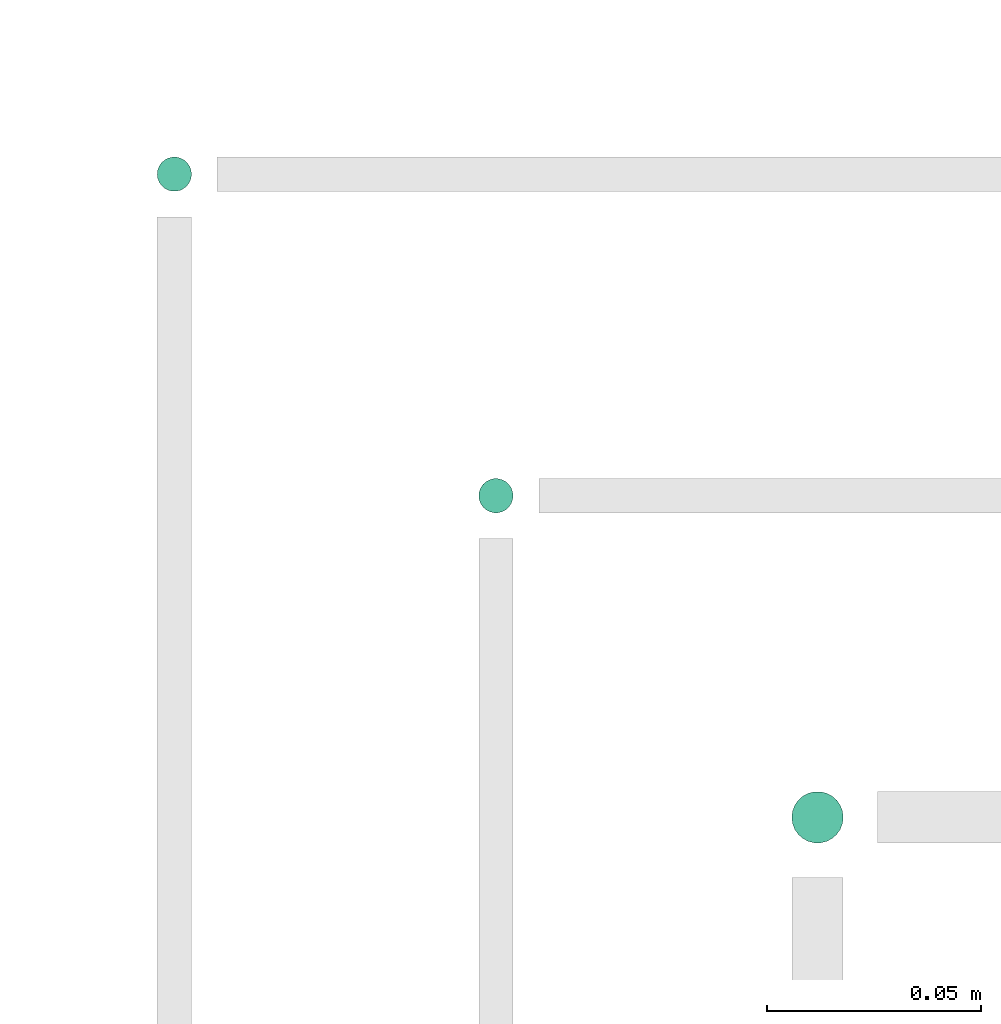
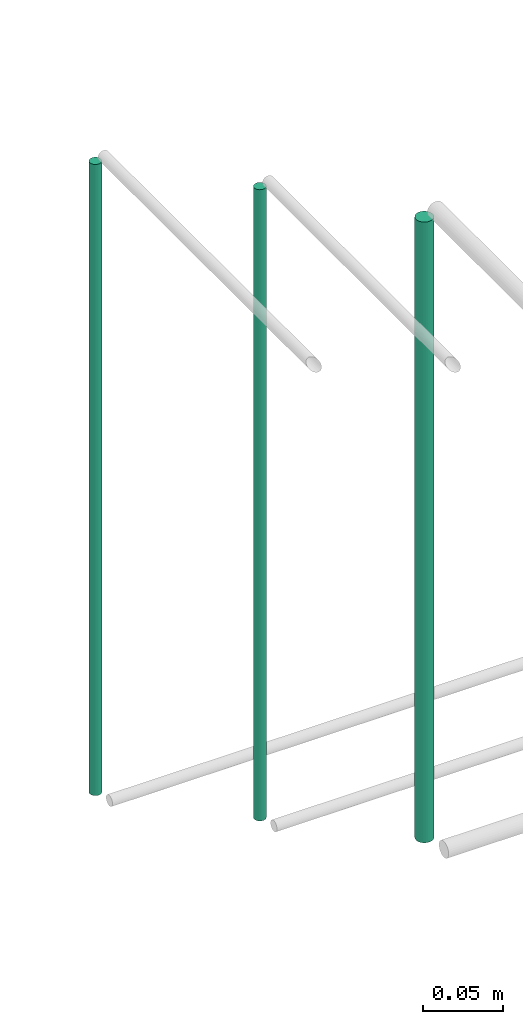
# One storey, part 30 of 65: 3 flow segments.
"""IFC2X3 building model written with IfcOpenShell, lengths in millimetres."""

from ifc_helpers import new_model, entity, si_unit, converted_unit, derived_unit, direction, frame, origin, origin_2d_with_axis, place, context, subcontext, project, spatial, circle, extrude, type_object, element, save


model = new_model("IFC2X3")

# Units and contexts
model_context = context("Model", 3, precision=0.01, world=origin(), true_north=direction((6.12303176911189e-17, 1.0)))
body_context = subcontext(model_context, "Body", "Model", "MODEL_VIEW")
ifc_project = project(units=[si_unit("LENGTHUNIT", "METRE", prefix="MILLI"), si_unit("AREAUNIT", "SQUARE_METRE"), si_unit("VOLUMEUNIT", "CUBIC_METRE"), converted_unit("PLANEANGLEUNIT", "DEGREE", entity("IfcRatioMeasure", 0.0174532925199433), si_unit("PLANEANGLEUNIT", "RADIAN"), dimensions=[0, 0, 0, 0, 0, 0, 0]), si_unit("MASSUNIT", "GRAM", prefix="KILO"), derived_unit("MASSDENSITYUNIT", [(si_unit("MASSUNIT", "GRAM", prefix="KILO"), 1), (si_unit("LENGTHUNIT", "METRE"), -3)]), derived_unit("MOMENTOFINERTIAUNIT", [(si_unit("LENGTHUNIT", "METRE"), 4)]), si_unit("TIMEUNIT", "SECOND"), si_unit("FREQUENCYUNIT", "HERTZ"), si_unit("THERMODYNAMICTEMPERATUREUNIT", "DEGREE_CELSIUS"), derived_unit("THERMALTRANSMITTANCEUNIT", [(si_unit("MASSUNIT", "GRAM", prefix="KILO"), 1), (si_unit("THERMODYNAMICTEMPERATUREUNIT", "KELVIN"), -1), (si_unit("TIMEUNIT", "SECOND"), -3)]), derived_unit("VOLUMETRICFLOWRATEUNIT", [(si_unit("LENGTHUNIT", "METRE"), 3), (si_unit("TIMEUNIT", "SECOND"), -1)]), derived_unit("MASSFLOWRATEUNIT", [(si_unit("MASSUNIT", "GRAM", prefix="KILO"), 1), (si_unit("TIMEUNIT", "SECOND"), -1)]), derived_unit("ROTATIONALFREQUENCYUNIT", [(si_unit("TIMEUNIT", "SECOND"), -1)]), si_unit("ELECTRICCURRENTUNIT", "AMPERE"), si_unit("ELECTRICVOLTAGEUNIT", "VOLT"), si_unit("POWERUNIT", "WATT"), si_unit("FORCEUNIT", "NEWTON", prefix="KILO"), si_unit("ILLUMINANCEUNIT", "LUX"), si_unit("LUMINOUSFLUXUNIT", "LUMEN"), si_unit("LUMINOUSINTENSITYUNIT", "CANDELA"), derived_unit("USERDEFINED", [(si_unit("MASSUNIT", "GRAM", prefix="KILO"), -1), (si_unit("LENGTHUNIT", "METRE"), -2), (si_unit("TIMEUNIT", "SECOND"), 3), (si_unit("LUMINOUSFLUXUNIT", "LUMEN"), 1)]), derived_unit("LINEARVELOCITYUNIT", [(si_unit("LENGTHUNIT", "METRE"), 1), (si_unit("TIMEUNIT", "SECOND"), -1)]), si_unit("PRESSUREUNIT", "PASCAL"), derived_unit("USERDEFINED", [(si_unit("LENGTHUNIT", "METRE"), -2), (si_unit("MASSUNIT", "GRAM", prefix="KILO"), 1), (si_unit("TIMEUNIT", "SECOND"), -2)]), derived_unit("LINEARFORCEUNIT", [(si_unit("MASSUNIT", "GRAM", prefix="KILO"), 1), (si_unit("LENGTHUNIT", "METRE"), 1), (si_unit("TIMEUNIT", "SECOND"), -2), (si_unit("LENGTHUNIT", "METRE"), -1)]), derived_unit("PLANARFORCEUNIT", [(si_unit("MASSUNIT", "GRAM", prefix="KILO"), 1), (si_unit("LENGTHUNIT", "METRE"), 1), (si_unit("TIMEUNIT", "SECOND"), -2), (si_unit("LENGTHUNIT", "METRE"), -2)])], contexts=[model_context])

# Site, building, storey
site_placement = place(None, frame((0.0, -0.00077364408347762, 0.0)))
site = spatial("IfcSite", under=ifc_project, at=site_placement, CompositionType="ELEMENT")
building_placement = place(site_placement, origin())
building = spatial("IfcBuilding", under=site, at=building_placement, CompositionType="ELEMENT")
storey_placement = place(building_placement, frame((0.0, 0.0, 19800.0)))
storey = spatial("IfcBuildingStorey", under=building, at=storey_placement, CompositionType="ELEMENT", Elevation=19800.0)

# Flow segments
pipe_segment_type = type_object("IfcPipeSegmentType", PredefinedType="NOTDEFINED")
flow_segment_1_placement = place(storey_placement, frame((33514.5162722351, 4824.40472776431, 2559.99998729136)))
element("IfcFlowSegment", 1, at=flow_segment_1_placement, inside=storey, type_object=pipe_segment_type, context=body_context, shape_type="SweptSolid", body=[
    extrude(circle(Radius=4.0, at=origin_2d_with_axis()), frame((5.5967972719551, 5.59527223591607, 1.27086325846904e-05)), (0.0, 0.0, 1.0), 480.000092361446),
])
flow_segment_2_placement = place(storey_placement, frame((33589.5177972714, 4749.40472776408, 2560.0)))
element("IfcFlowSegment", 2, at=flow_segment_2_placement, inside=storey, type_object=pipe_segment_type, context=body_context, shape_type="SweptSolid", body=[
    extrude(circle(Radius=4.0, at=origin_2d_with_axis()), frame((5.59527223591499, 5.59527223591607, 0.0)), (0.0, 0.0, 1.0), 480.000000000012),
])
flow_segment_3_placement = place(storey_placement, frame((33662.5177972714, 4672.40472776408, 2564.0)))
element("IfcFlowSegment", 3, at=flow_segment_3_placement, inside=storey, type_object=pipe_segment_type, context=body_context, shape_type="SweptSolid", body=[
    extrude(circle(Radius=6.0, at=origin_2d_with_axis()), frame((7.59527223591454, 7.59527223591616, 0.0)), (0.0, 0.0, 1.0), 472.000000000005),
])

save(model, "model.ifc")
